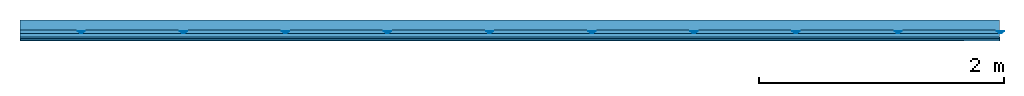
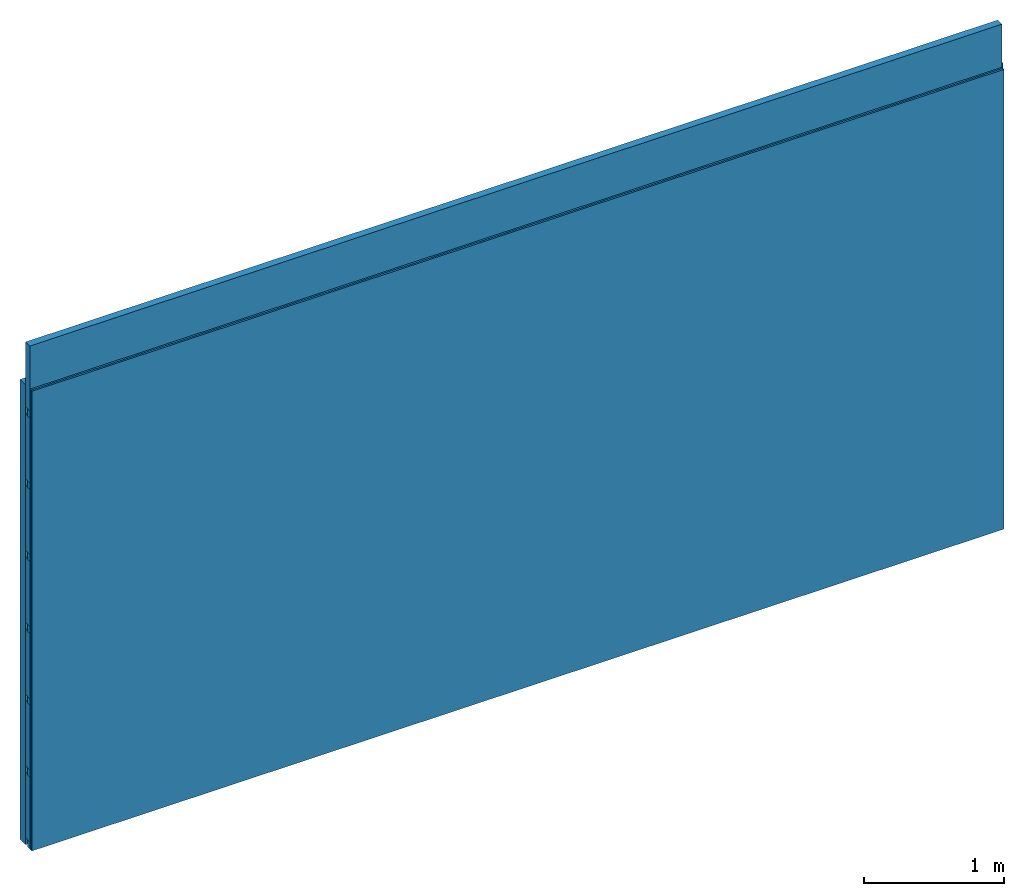
# One storey: 4 members, 2 plates, 1 element without a shape of its own.
"""IFC4 building model written with IfcOpenShell, lengths in metres."""

import ifcopenshell
import ifcopenshell.guid

model = None  # the IFC model being written
_history = None  # IfcOwnerHistory: only IFC2X3 demands one
_inside = {}  # id of a spatial element -> (the spatial element, [elements in it])
_under = {}  # id of a project, library or spatial element -> (it, [spatial elements below it])
_declared = {}  # id of a project -> (the project, [libraries it declares])
_typed = {}  # id of a type object -> (the type object, [elements of that type])
_made_of = {}  # id of a material, layer set ... -> (it, [elements and type objects made of it])


def new_model(schema):
    """Start an empty IFC model of exactly this schema.

    Asked for "IFC4X3", IfcOpenShell would pick the latest addendum, in which some entities
    have other attributes; the version numbers below select the first issue.
    IFC2X3 requires an IfcOwnerHistory on every rooted entity: one is made here for all.
    """
    global model, _history
    if schema == "IFC4X3":
        model = ifcopenshell.file(schema_version=(4, 3, 0, 0))
    else:
        model = ifcopenshell.file(schema=schema)
    _inside.clear()
    _under.clear()
    _declared.clear()
    _typed.clear()
    _made_of.clear()
    _history = None
    if model.schema == "IFC2X3":
        org = make("IfcOrganization", Name="unknown")
        user = make(
            "IfcPersonAndOrganization",
            ThePerson=make("IfcPerson", FamilyName="unknown"),
            TheOrganization=org,
        )
        app = make(
            "IfcApplication",
            ApplicationDeveloper=org,
            Version="unknown",
            ApplicationFullName="unknown",
            ApplicationIdentifier="unknown",
        )
        _history = make(
            "IfcOwnerHistory",
            OwningUser=user,
            OwningApplication=app,
            ChangeAction="ADDED",
            CreationDate=0,
        )
    return model


def make(cls, **values):
    """One entity of the class cls with the attributes given. An attribute that is None is left unset."""
    return model.create_entity(
        cls, **{name: value for name, value in values.items() if value is not None}
    )


def rooted(cls, **values):
    """An entity with a GlobalId (a new one), such as an element, a storey or a relation."""
    return make(cls, GlobalId=ifcopenshell.guid.new(), OwnerHistory=_history, **values)


def si_unit(unit_type, name, prefix=None):
    """IfcSIUnit, for example si_unit("LENGTHUNIT", "METRE", prefix="MILLI")."""
    return make("IfcSIUnit", UnitType=unit_type, Prefix=prefix, Name=name)


def derived_unit(unit_type, elements):
    """IfcDerivedUnit: a product of units, each with its exponent."""
    return make(
        "IfcDerivedUnit",
        Elements=[
            make("IfcDerivedUnitElement", Unit=unit, Exponent=power)
            for unit, power in elements
        ],
        UnitType=unit_type,
    )


def assignment(units):
    """IfcUnitAssignment: the units of a project."""
    return None if units is None else make("IfcUnitAssignment", Units=units)


def point(xyz):
    """IfcCartesianPoint."""
    return None if xyz is None else make("IfcCartesianPoint", Coordinates=xyz)


def direction(xyz):
    """IfcDirection."""
    return None if xyz is None else make("IfcDirection", DirectionRatios=xyz)


def frame(location, z_axis=None, x_axis=None):
    """IfcAxis2Placement3D, a coordinate frame: its origin and axes. An axis left out is left unset."""
    return make(
        "IfcAxis2Placement3D",
        Location=point(location),
        Axis=direction(z_axis),
        RefDirection=direction(x_axis),
    )


def frame_2d(location, x_axis=None):
    """IfcAxis2Placement2D, a coordinate frame in the plane: its origin and x axis."""
    return make(
        "IfcAxis2Placement2D", Location=point(location), RefDirection=direction(x_axis)
    )


def origin():
    """The frame at (0, 0, 0) with its axes left unset."""
    return frame((0.0, 0.0, 0.0))


def place(relative_to, where):
    """IfcLocalPlacement: puts the frame where relative to a parent placement (None: the world)."""
    return make(
        "IfcLocalPlacement", PlacementRelTo=relative_to, RelativePlacement=where
    )


def context(
    kind, dimensions, precision=None, world=None, true_north=None, identifier=None
):
    """IfcGeometricRepresentationContext, for example the 3D "Model" context."""
    return make(
        "IfcGeometricRepresentationContext",
        ContextIdentifier=identifier,
        ContextType=kind,
        CoordinateSpaceDimension=dimensions,
        Precision=precision,
        WorldCoordinateSystem=world,
        TrueNorth=true_north,
    )


def project(units=None, contexts=None):
    """IfcProject with its units and contexts."""
    return rooted(
        "IfcProject",
        Name="project",
        RepresentationContexts=contexts,
        UnitsInContext=assignment(units),
    )


def spatial(cls, under=None, at=None, **own):
    """A site, building, storey or space (cls), placed at a placement, below another one or the project."""
    s = rooted(cls, ObjectPlacement=at, **own)
    if under is not None:
        _under.setdefault(under.id(), (under, []))[1].append(s)
    return s


def polyline(points):
    """IfcPolyline through the points."""
    return make("IfcPolyline", Points=[point(p) for p in points])


def profile(cls, at=None, kind="AREA", **sizes):
    """A parametric profile (cls). Its sizes go by their IFC names, for example OverallWidth=200.0."""
    return make(cls, ProfileType=kind, Position=at, **sizes)


def rectangle(**sizes):
    """IfcRectangleProfileDef."""
    return profile("IfcRectangleProfileDef", **sizes)


def outline(outer, holes=None, kind="AREA"):
    """IfcArbitraryClosedProfileDef: a profile drawn as a closed curve; with holes, ...WithVoids."""
    if holes is None:
        return make("IfcArbitraryClosedProfileDef", ProfileType=kind, OuterCurve=outer)
    return make(
        "IfcArbitraryProfileDefWithVoids",
        ProfileType=kind,
        OuterCurve=outer,
        InnerCurves=holes,
    )


def extrude(swept, where, along, depth):
    """IfcExtrudedAreaSolid: the profile swept, set in the frame where, extruded along a direction by depth."""
    return make(
        "IfcExtrudedAreaSolid",
        SweptArea=swept,
        Position=where,
        ExtrudedDirection=direction(along),
        Depth=depth,
    )


def shape(context_of_items, identifier, shape_type, items):
    """IfcShapeRepresentation: the items that make up one representation, for example the "Body"."""
    return make(
        "IfcShapeRepresentation",
        ContextOfItems=context_of_items,
        RepresentationIdentifier=identifier,
        RepresentationType=shape_type,
        Items=items,
    )


def material(Name=None, Category=None):
    """IfcMaterial."""
    return make("IfcMaterial", Name=Name, Category=Category)


def layer(
    of_material, thickness, ventilated=None, Name=None, Category=None, Priority=None
):
    """IfcMaterialLayer: one layer of a wall or slab, of a material (None: an air gap)."""
    return make(
        "IfcMaterialLayer",
        Material=of_material,
        LayerThickness=thickness,
        IsVentilated=ventilated,
        Name=Name,
        Category=Category,
        Priority=Priority,
    )


def layer_set(layers, Name=None):
    """IfcMaterialLayerSet."""
    return make("IfcMaterialLayerSet", MaterialLayers=layers, LayerSetName=Name)


def made_of(thing, what):
    """Note that an element or type object is made of a material, layer set ...; save() writes the relation."""
    if what is not None:
        _made_of.setdefault(what.id(), (what, []))[1].append(thing)
    return thing


def type_object(cls, material=None, **own):
    """A type object (cls), such as IfcWallType, which elements share."""
    return made_of(rooted(cls, **own), material)


def element(
    cls,
    number,
    at=None,
    inside=None,
    cuts=None,
    type_object=None,
    material=None,
    context=None,
    identifier="Body",
    shape_type=None,
    held_by="IfcProductDefinitionShape",
    body=None,
    shapes=None,
    **own,
):
    """One element of the class cls, such as IfcWall. Its Tag is "e" and its number.

    at: its placement. inside: the storey or other place that contains it. cuts: it is an
    opening in that element (IfcRelVoidsElement). A single representation is given by context,
    identifier, shape_type and body (its items); several are given by shapes. held_by: the class
    of the entity that holds the representations. save() writes the other relations.
    """
    e = rooted(cls, Tag="e%d" % number, ObjectPlacement=at, **own)
    if body is not None:
        shapes = [shape(context, identifier, shape_type, body)]
    if shapes is not None:
        e.Representation = make(held_by, Representations=shapes)
    if inside is not None:
        _inside.setdefault(inside.id(), (inside, []))[1].append(e)
    if cuts is not None:
        rooted(
            "IfcRelVoidsElement", RelatingBuildingElement=cuts, RelatedOpeningElement=e
        )
    if type_object is not None:
        _typed.setdefault(type_object.id(), (type_object, []))[1].append(e)
    return made_of(e, material)


def aggregate(whole, parts):
    """IfcRelAggregates: a whole, such as a stair, and the parts it consists of."""
    return rooted("IfcRelAggregates", RelatingObject=whole, RelatedObjects=parts)


def save(model, path):
    """Write the relations noted so far, then the file.

    IfcRelAggregates (storeys below a building ...), IfcRelContainedInSpatialStructure (elements
    in a storey), IfcRelDefinesByType, IfcRelAssociatesMaterial and IfcRelDeclares: one each for
    every whole, place, type object, material and project.
    """
    for whole, parts in _under.values():
        aggregate(whole, parts)
    for where, things in _inside.values():
        rooted(
            "IfcRelContainedInSpatialStructure",
            RelatedElements=things,
            RelatingStructure=where,
        )
    for kind, things in _typed.values():
        rooted("IfcRelDefinesByType", RelatedObjects=things, RelatingType=kind)
    for what, things in _made_of.values():
        rooted("IfcRelAssociatesMaterial", RelatedObjects=things, RelatingMaterial=what)
    for by, libraries in _declared.values():
        rooted("IfcRelDeclares", RelatingContext=by, RelatedDefinitions=libraries)
    model.write(path)


model = new_model("IFC4")

# Units and contexts
plan_context = context("Plan", 3, precision=1e-05, world=origin(), true_north=direction((0.0, 1.0)))
model_context = context("Model", 3, precision=1e-05, world=origin(), true_north=direction((0.0, 1.0)))
ifc_project = project(units=[si_unit("LENGTHUNIT", "METRE"), derived_unit("SOUNDPRESSUREUNIT", [(si_unit("PRESSUREUNIT", "PASCAL", prefix="MICRO"), 0)]), si_unit("ENERGYUNIT", "JOULE", prefix="MEGA"), si_unit("MASSUNIT", "GRAM", prefix="KILO"), derived_unit("THERMALTRANSMITTANCEUNIT", [(si_unit("POWERUNIT", "WATT"), 1), (si_unit("AREAUNIT", "SQUARE_METRE"), -1), (si_unit("THERMODYNAMICTEMPERATUREUNIT", "KELVIN"), -1)]), derived_unit("AREADENSITYUNIT", [(si_unit("MASSUNIT", "GRAM", prefix="KILO"), 1), (si_unit("AREAUNIT", "SQUARE_METRE"), -1)]), derived_unit("USERDEFINED", [(si_unit("ENERGYUNIT", "JOULE", prefix="MEGA"), 1), (si_unit("AREAUNIT", "SQUARE_METRE"), -1)])], contexts=[plan_context, model_context])

# Site, building, storey
site = spatial("IfcSite", under=ifc_project)
building_placement = place(None, origin())
building = spatial("IfcBuilding", under=site, at=building_placement)
storey_placement = place(building_placement, origin())
storey = spatial("IfcBuildingStorey", under=building, at=storey_placement)

# Wall, members, plates
ifc_layer_1 = layer(None, 0.08, Name="Support")
ifc_material_1 = material(Name="no composite action")
ifc_layer_2 = layer(ifc_material_1, 0.0, Name="Bond")
ifc_layer_3 = layer(None, 0.03, Name="Coupling")
ifc_layer_4 = layer(None, 0.03, Name="Battens / profiles")
ifc_material_2 = material(Name="Plasterboard type A", Category="03.008")
ifc_layer_5 = layer(ifc_material_2, 0.015, Name="Covering 1st layer")
ifc_layer_6 = layer(ifc_material_2, 0.015, Name="Covering 2nd layer")
ifc_material_3 = material(Name="joints", Category="04.017")
ifc_layer_7 = layer(ifc_material_3, 0.0, Name="Surface")
ifc_layer_set = layer_set([ifc_layer_1, ifc_layer_2, ifc_layer_3, ifc_layer_4, ifc_layer_5, ifc_layer_6, ifc_layer_7])
wall_type = type_object("IfcWallType", Name="C0104", PredefinedType="NOTDEFINED", material=ifc_layer_set)
wall_placement = place(None, frame((0.0, 0.0, 0.0), z_axis=(0.0, -1.0, 0.0), x_axis=(1.0, 0.0, 0.0)))
wall = element("IfcWall", 1, at=wall_placement, inside=storey, type_object=wall_type, material=ifc_layer_set, Name="Wall #1")
ifc_material_4 = material()
member_1_placement = place(wall_placement, origin())
member_1 = element("IfcMember", 2, at=member_1_placement, material=ifc_material_4, Name="Support", context=plan_context, shape_type="SweptSolid", body=[
    extrude(rectangle(XDim=1.0, YDim=0.08, at=frame_2d((0.5, 0.04), x_axis=(1.0, 0.0))), frame((0.0, 4.0, 0.0), z_axis=(0.0, -1.0, 0.0), x_axis=(1.0, 0.0, 0.0)), (0.0, 0.0, 1.0), 4.0),
    extrude(rectangle(XDim=1.0, YDim=0.08, at=frame_2d((0.5, 0.04), x_axis=(1.0, 0.0))), frame((1.0, 4.0, 0.0), z_axis=(0.0, -1.0, 0.0), x_axis=(1.0, 0.0, 0.0)), (0.0, 0.0, 1.0), 4.0),
    extrude(rectangle(XDim=1.0, YDim=0.08, at=frame_2d((0.5, 0.04), x_axis=(1.0, 0.0))), frame((2.0, 4.0, 0.0), z_axis=(0.0, -1.0, 0.0), x_axis=(1.0, 0.0, 0.0)), (0.0, 0.0, 1.0), 4.0),
    extrude(rectangle(XDim=1.0, YDim=0.08, at=frame_2d((0.5, 0.04), x_axis=(1.0, 0.0))), frame((3.0, 4.0, 0.0), z_axis=(0.0, -1.0, 0.0), x_axis=(1.0, 0.0, 0.0)), (0.0, 0.0, 1.0), 4.0),
    extrude(rectangle(XDim=1.0, YDim=0.08, at=frame_2d((0.5, 0.04), x_axis=(1.0, 0.0))), frame((4.0, 4.0, 0.0), z_axis=(0.0, -1.0, 0.0), x_axis=(1.0, 0.0, 0.0)), (0.0, 0.0, 1.0), 4.0),
    extrude(rectangle(XDim=1.0, YDim=0.08, at=frame_2d((0.5, 0.04), x_axis=(1.0, 0.0))), frame((5.0, 4.0, 0.0), z_axis=(0.0, -1.0, 0.0), x_axis=(1.0, 0.0, 0.0)), (0.0, 0.0, 1.0), 4.0),
    extrude(rectangle(XDim=1.0, YDim=0.08, at=frame_2d((0.5, 0.04), x_axis=(1.0, 0.0))), frame((6.0, 4.0, 0.0), z_axis=(0.0, -1.0, 0.0), x_axis=(1.0, 0.0, 0.0)), (0.0, 0.0, 1.0), 4.0),
    extrude(rectangle(XDim=1.0, YDim=0.08, at=frame_2d((0.5, 0.04), x_axis=(1.0, 0.0))), frame((7.0, 4.0, 0.0), z_axis=(0.0, -1.0, 0.0), x_axis=(1.0, 0.0, 0.0)), (0.0, 0.0, 1.0), 4.0),
])
ifc_material_5 = material()
member_2_placement = place(wall_placement, origin())
member_2 = element("IfcMember", 3, at=member_2_placement, material=ifc_material_5, Name="Coupling", context=plan_context, shape_type="SweptSolid", body=[
    extrude(outline(polyline([(0.0, 0.0), (0.06, 0.0), (0.04, 0.02), (0.02, 0.02), (0.0, 0.0)])), frame((0.47, 4.0, 0.09), z_axis=(0.0, -1.0, 0.0), x_axis=(1.0, 0.0, 0.0)), (0.0, 0.0, 1.0), 4.0),
    extrude(outline(polyline([(0.0, 0.0), (0.06, 0.0), (0.04, 0.02), (0.02, 0.02), (0.0, 0.0)])), frame((1.304, 4.0, 0.09), z_axis=(0.0, -1.0, 0.0), x_axis=(1.0, 0.0, 0.0)), (0.0, 0.0, 1.0), 4.0),
    extrude(outline(polyline([(0.0, 0.0), (0.06, 0.0), (0.04, 0.02), (0.02, 0.02), (0.0, 0.0)])), frame((2.138, 4.0, 0.09), z_axis=(0.0, -1.0, 0.0), x_axis=(1.0, 0.0, 0.0)), (0.0, 0.0, 1.0), 4.0),
    extrude(outline(polyline([(0.0, 0.0), (0.06, 0.0), (0.04, 0.02), (0.02, 0.02), (0.0, 0.0)])), frame((2.972, 4.0, 0.09), z_axis=(0.0, -1.0, 0.0), x_axis=(1.0, 0.0, 0.0)), (0.0, 0.0, 1.0), 4.0),
    extrude(outline(polyline([(0.0, 0.0), (0.06, 0.0), (0.04, 0.02), (0.02, 0.02), (0.0, 0.0)])), frame((3.806, 4.0, 0.09), z_axis=(0.0, -1.0, 0.0), x_axis=(1.0, 0.0, 0.0)), (0.0, 0.0, 1.0), 4.0),
    extrude(outline(polyline([(0.0, 0.0), (0.06, 0.0), (0.04, 0.02), (0.02, 0.02), (0.0, 0.0)])), frame((4.64, 4.0, 0.09), z_axis=(0.0, -1.0, 0.0), x_axis=(1.0, 0.0, 0.0)), (0.0, 0.0, 1.0), 4.0),
    extrude(outline(polyline([(0.0, 0.0), (0.06, 0.0), (0.04, 0.02), (0.02, 0.02), (0.0, 0.0)])), frame((5.474, 4.0, 0.09), z_axis=(0.0, -1.0, 0.0), x_axis=(1.0, 0.0, 0.0)), (0.0, 0.0, 1.0), 4.0),
    extrude(outline(polyline([(0.0, 0.0), (0.06, 0.0), (0.04, 0.02), (0.02, 0.02), (0.0, 0.0)])), frame((6.308, 4.0, 0.09), z_axis=(0.0, -1.0, 0.0), x_axis=(1.0, 0.0, 0.0)), (0.0, 0.0, 1.0), 4.0),
    extrude(outline(polyline([(0.0, 0.0), (0.06, 0.0), (0.04, 0.02), (0.02, 0.02), (0.0, 0.0)])), frame((7.142, 4.0, 0.09), z_axis=(0.0, -1.0, 0.0), x_axis=(1.0, 0.0, 0.0)), (0.0, 0.0, 1.0), 4.0),
    extrude(outline(polyline([(0.0, 0.0), (0.06, 0.0), (0.04, 0.02), (0.02, 0.02), (0.0, 0.0)])), frame((7.976, 4.0, 0.09), z_axis=(0.0, -1.0, 0.0), x_axis=(1.0, 0.0, 0.0)), (0.0, 0.0, 1.0), 4.0),
])
member_3_placement = place(wall_placement, origin())
member_3 = element("IfcMember", 4, at=member_3_placement, material=ifc_material_5, Name="Battens / profiles", context=plan_context, shape_type="SweptSolid", body=[
    extrude(rectangle(XDim=0.06, YDim=0.03, at=frame_2d((0.03, 0.015), x_axis=(1.0, 0.0))), frame((0.0, 0.0, 0.11), z_axis=(1.0, 0.0, 0.0), x_axis=(0.0, 1.0, 0.0)), (0.0, 0.0, 1.0), 8.0),
    extrude(rectangle(XDim=0.06, YDim=0.03, at=frame_2d((0.03, 0.015), x_axis=(1.0, 0.0))), frame((0.0, 0.625, 0.11), z_axis=(1.0, 0.0, 0.0), x_axis=(0.0, 1.0, 0.0)), (0.0, 0.0, 1.0), 8.0),
    extrude(rectangle(XDim=0.06, YDim=0.03, at=frame_2d((0.03, 0.015), x_axis=(1.0, 0.0))), frame((0.0, 1.25, 0.11), z_axis=(1.0, 0.0, 0.0), x_axis=(0.0, 1.0, 0.0)), (0.0, 0.0, 1.0), 8.0),
    extrude(rectangle(XDim=0.06, YDim=0.03, at=frame_2d((0.03, 0.015), x_axis=(1.0, 0.0))), frame((0.0, 1.875, 0.11), z_axis=(1.0, 0.0, 0.0), x_axis=(0.0, 1.0, 0.0)), (0.0, 0.0, 1.0), 8.0),
    extrude(rectangle(XDim=0.06, YDim=0.03, at=frame_2d((0.03, 0.015), x_axis=(1.0, 0.0))), frame((0.0, 2.5, 0.11), z_axis=(1.0, 0.0, 0.0), x_axis=(0.0, 1.0, 0.0)), (0.0, 0.0, 1.0), 8.0),
    extrude(rectangle(XDim=0.06, YDim=0.03, at=frame_2d((0.03, 0.015), x_axis=(1.0, 0.0))), frame((0.0, 3.125, 0.11), z_axis=(1.0, 0.0, 0.0), x_axis=(0.0, 1.0, 0.0)), (0.0, 0.0, 1.0), 8.0),
    extrude(rectangle(XDim=0.06, YDim=0.03, at=frame_2d((0.03, 0.015), x_axis=(1.0, 0.0))), frame((0.0, 3.75, 0.11), z_axis=(1.0, 0.0, 0.0), x_axis=(0.0, 1.0, 0.0)), (0.0, 0.0, 1.0), 8.0),
])
ifc_material_6 = material()
member_4_placement = place(wall_placement, origin())
member_4 = element("IfcMember", 5, at=member_4_placement, material=ifc_material_6, Name="Cavity", context=plan_context, shape_type="SweptSolid", body=[
    extrude(rectangle(XDim=0.565, YDim=0.06, at=frame_2d((0.2825, 0.03), x_axis=(1.0, 0.0))), frame((0.0, 0.06, 0.08), z_axis=(1.0, 0.0, 0.0), x_axis=(0.0, 1.0, 0.0)), (0.0, 0.0, 1.0), 8.0),
    extrude(rectangle(XDim=0.565, YDim=0.06, at=frame_2d((0.2825, 0.03), x_axis=(1.0, 0.0))), frame((0.0, 0.685, 0.08), z_axis=(1.0, 0.0, 0.0), x_axis=(0.0, 1.0, 0.0)), (0.0, 0.0, 1.0), 8.0),
    extrude(rectangle(XDim=0.565, YDim=0.06, at=frame_2d((0.2825, 0.03), x_axis=(1.0, 0.0))), frame((0.0, 1.31, 0.08), z_axis=(1.0, 0.0, 0.0), x_axis=(0.0, 1.0, 0.0)), (0.0, 0.0, 1.0), 8.0),
    extrude(rectangle(XDim=0.565, YDim=0.06, at=frame_2d((0.2825, 0.03), x_axis=(1.0, 0.0))), frame((0.0, 1.935, 0.08), z_axis=(1.0, 0.0, 0.0), x_axis=(0.0, 1.0, 0.0)), (0.0, 0.0, 1.0), 8.0),
    extrude(rectangle(XDim=0.565, YDim=0.06, at=frame_2d((0.2825, 0.03), x_axis=(1.0, 0.0))), frame((0.0, 2.56, 0.08), z_axis=(1.0, 0.0, 0.0), x_axis=(0.0, 1.0, 0.0)), (0.0, 0.0, 1.0), 8.0),
    extrude(rectangle(XDim=0.565, YDim=0.06, at=frame_2d((0.2825, 0.03), x_axis=(1.0, 0.0))), frame((0.0, 3.185, 0.08), z_axis=(1.0, 0.0, 0.0), x_axis=(0.0, 1.0, 0.0)), (0.0, 0.0, 1.0), 8.0),
    extrude(rectangle(XDim=0.565, YDim=0.06, at=frame_2d((0.2825, 0.03), x_axis=(1.0, 0.0))), frame((0.0, 3.81, 0.08), z_axis=(1.0, 0.0, 0.0), x_axis=(0.0, 1.0, 0.0)), (0.0, 0.0, 1.0), 8.0),
])
plate_1_placement = place(wall_placement, origin())
plate_1 = element("IfcPlate", 6, at=plate_1_placement, material=ifc_material_2, Name="Covering 1st layer", context=plan_context, shape_type="SweptSolid", body=[
    extrude(rectangle(XDim=8.0, YDim=4.0, at=frame_2d((4.0, 2.0), x_axis=(1.0, 0.0))), frame((0.0, 0.0, 0.14), z_axis=(0.0, 0.0, 1.0), x_axis=(1.0, 0.0, 0.0)), (0.0, 0.0, 1.0), 0.015),
])
plate_2_placement = place(wall_placement, origin())
plate_2 = element("IfcPlate", 7, at=plate_2_placement, material=ifc_material_2, Name="Covering 2nd layer", context=plan_context, shape_type="SweptSolid", body=[
    extrude(rectangle(XDim=8.0, YDim=4.0, at=frame_2d((4.0, 2.0), x_axis=(1.0, 0.0))), frame((0.0, 0.0, 0.155), z_axis=(0.0, 0.0, 1.0), x_axis=(1.0, 0.0, 0.0)), (0.0, 0.0, 1.0), 0.015),
])
aggregate(wall, [member_1, member_2, member_3, member_4, plate_1, plate_2])

save(model, "model.ifc")
